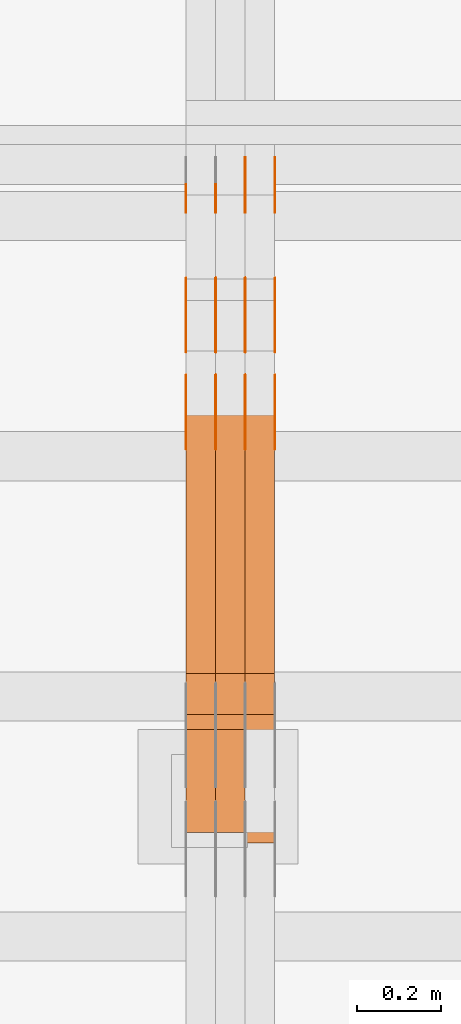
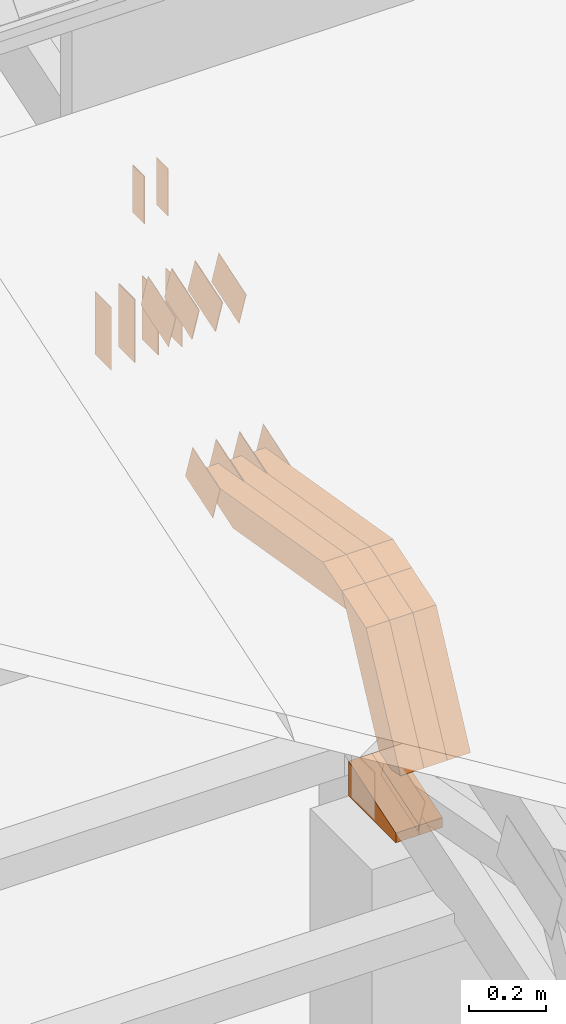
# One storey, part 143 of 385: 29 proxies.
"""IFC2X3 building model written with IfcOpenShell, lengths in millimetres."""

from ifc_helpers import new_model, entity, si_unit, converted_unit, derived_unit, direction, frame, frame_2d, origin, origin_2d_with_axis, place, context, subcontext, project, spatial, polyline, rectangle, outline, extrude, source, transform, mapped, material, type_object, type_shapes, element, save


model = new_model("IFC2X3")

# Units and contexts
model_context = context("Model", 3, precision=0.01, world=origin(), true_north=direction((6.12303176911189e-17, 1.0)))
body_context = subcontext(model_context, "Body", "Model", "MODEL_VIEW")
ifc_project = project(units=[si_unit("LENGTHUNIT", "METRE", prefix="MILLI"), si_unit("AREAUNIT", "SQUARE_METRE"), si_unit("VOLUMEUNIT", "CUBIC_METRE"), converted_unit("PLANEANGLEUNIT", "DEGREE", entity("IfcRatioMeasure", 0.0174532925199433), si_unit("PLANEANGLEUNIT", "RADIAN"), dimensions=[0, 0, 0, 0, 0, 0, 0]), si_unit("MASSUNIT", "GRAM", prefix="KILO"), derived_unit("MASSDENSITYUNIT", [(si_unit("MASSUNIT", "GRAM", prefix="KILO"), 1), (si_unit("LENGTHUNIT", "METRE"), -3)]), si_unit("TIMEUNIT", "SECOND"), si_unit("FREQUENCYUNIT", "HERTZ"), si_unit("THERMODYNAMICTEMPERATUREUNIT", "DEGREE_CELSIUS"), derived_unit("THERMALTRANSMITTANCEUNIT", [(si_unit("MASSUNIT", "GRAM", prefix="KILO"), 1), (si_unit("THERMODYNAMICTEMPERATUREUNIT", "KELVIN"), -1), (si_unit("TIMEUNIT", "SECOND"), -3)]), derived_unit("VOLUMETRICFLOWRATEUNIT", [(si_unit("LENGTHUNIT", "METRE"), 3), (si_unit("TIMEUNIT", "SECOND"), -1)]), si_unit("ELECTRICCURRENTUNIT", "AMPERE"), si_unit("ELECTRICVOLTAGEUNIT", "VOLT"), si_unit("POWERUNIT", "WATT"), si_unit("FORCEUNIT", "NEWTON", prefix="KILO"), si_unit("ILLUMINANCEUNIT", "LUX"), si_unit("LUMINOUSFLUXUNIT", "LUMEN"), si_unit("LUMINOUSINTENSITYUNIT", "CANDELA"), derived_unit("USERDEFINED", [(si_unit("MASSUNIT", "GRAM", prefix="KILO"), -1), (si_unit("LENGTHUNIT", "METRE"), -2), (si_unit("TIMEUNIT", "SECOND"), 3), (si_unit("LUMINOUSFLUXUNIT", "LUMEN"), 1)]), derived_unit("LINEARVELOCITYUNIT", [(si_unit("LENGTHUNIT", "METRE"), 1), (si_unit("TIMEUNIT", "SECOND"), -1)]), si_unit("PRESSUREUNIT", "PASCAL"), derived_unit("USERDEFINED", [(si_unit("LENGTHUNIT", "METRE"), -2), (si_unit("MASSUNIT", "GRAM", prefix="KILO"), 1), (si_unit("TIMEUNIT", "SECOND"), -2)])], contexts=[model_context])

# Site, building, storey
site_placement = place(None, origin())
site = spatial("IfcSite", under=ifc_project, at=site_placement, CompositionType="ELEMENT")
building_placement = place(site_placement, origin())
building = spatial("IfcBuilding", under=site, at=building_placement, CompositionType="ELEMENT")
storey_placement = place(building_placement, origin())
storey = spatial("IfcBuildingStorey", under=building, at=storey_placement, Name="Default", CompositionType="ELEMENT", Elevation=0.0)

# Proxies
ifc_material_1 = material(Name="IfcSurfaceStyle #243572")
building_element_proxy_type_1 = type_object("IfcBuildingElementProxyType", PredefinedType="NOTDEFINED", material=ifc_material_1)
shared_shape_1 = source(origin(), body_context, "Body", "SweptSolid", [
    extrude(rectangle(XDim=200.0, YDim=84.0, at=frame_2d((0.0, -7.105427357601e-15), x_axis=(1.0, 0.0))), frame((100.0, 42.0, 0.0), z_axis=(0.0, 0.0, 1.0), x_axis=(-1.0, 0.0, 0.0)), (0.0, 0.0, 1.0), 1.3),
])
type_shapes(building_element_proxy_type_1, [shared_shape_1])
proxy_1_placement = place(building_placement, frame((18386.3, 13702.0, 3651.4150390625), z_axis=(-1.0, 0.0, 0.0), x_axis=(0.0, 0.0, -1.0)))
element("IfcBuildingElementProxy", 1, at=proxy_1_placement, inside=storey, type_object=building_element_proxy_type_1, material=ifc_material_1, context=body_context, shape_type="MappedRepresentation", body=[
    mapped(shared_shape_1, transform((0.0, 0.0, 0.0), scale=1.0)),
])
ifc_material_2 = material(Name="IfcSurfaceStyle #243515")
building_element_proxy_type_2 = type_object("IfcBuildingElementProxyType", PredefinedType="NOTDEFINED", material=ifc_material_2)
shared_shape_2 = source(origin(), body_context, "Body", "SweptSolid", [
    extrude(rectangle(XDim=200.0, YDim=84.0, at=frame_2d((0.0, -7.105427357601e-15), x_axis=(1.0, 0.0))), frame((100.0, 42.0, 0.0), z_axis=(0.0, 0.0, 1.0), x_axis=(-1.0, 0.0, 0.0)), (0.0, 0.0, 1.0), 1.3),
])
type_shapes(building_element_proxy_type_2, [shared_shape_2])
proxy_2_placement = place(building_placement, frame((18315.0, 13702.0, 3651.4150390625), z_axis=(-1.0, 0.0, 0.0), x_axis=(0.0, 0.0, -1.0)))
element("IfcBuildingElementProxy", 2, at=proxy_2_placement, inside=storey, type_object=building_element_proxy_type_2, material=ifc_material_2, context=body_context, shape_type="MappedRepresentation", body=[
    mapped(shared_shape_2, transform((0.0, 0.0, 0.0), scale=1.0)),
])
ifc_material_3 = material(Name="IfcSurfaceStyle #243458")
building_element_proxy_type_3 = type_object("IfcBuildingElementProxyType", PredefinedType="NOTDEFINED", material=ifc_material_3)
shared_shape_3 = source(origin(), body_context, "Body", "SweptSolid", [
    extrude(rectangle(XDim=200.0, YDim=84.0, at=frame_2d((0.0, -7.105427357601e-15), x_axis=(1.0, 0.0))), frame((100.0, 42.0, 0.0), z_axis=(0.0, 0.0, 1.0), x_axis=(-1.0, 0.0, 0.0)), (0.0, 0.0, 1.0), 1.3),
])
type_shapes(building_element_proxy_type_3, [shared_shape_3])
proxy_3_placement = place(building_placement, frame((18316.3, 13702.0, 3651.4150390625), z_axis=(-1.0, 0.0, 0.0), x_axis=(0.0, 0.0, -1.0)))
element("IfcBuildingElementProxy", 3, at=proxy_3_placement, inside=storey, type_object=building_element_proxy_type_3, material=ifc_material_3, context=body_context, shape_type="MappedRepresentation", body=[
    mapped(shared_shape_3, transform((0.0, 0.0, 0.0), scale=1.0)),
])
ifc_material_4 = material(Name="IfcSurfaceStyle #243401")
building_element_proxy_type_4 = type_object("IfcBuildingElementProxyType", PredefinedType="NOTDEFINED", material=ifc_material_4)
shared_shape_4 = source(origin(), body_context, "Body", "SweptSolid", [
    extrude(rectangle(XDim=200.0, YDim=84.0, at=frame_2d((0.0, -7.105427357601e-15), x_axis=(1.0, 0.0))), frame((100.0, 42.0, 0.0), z_axis=(0.0, 0.0, 1.0), x_axis=(-1.0, 0.0, 0.0)), (0.0, 0.0, 1.0), 1.29999999999998),
])
type_shapes(building_element_proxy_type_4, [shared_shape_4])
proxy_4_placement = place(building_placement, frame((18245.0, 13702.0, 3651.4150390625), z_axis=(-1.0, 0.0, 0.0), x_axis=(0.0, 0.0, -1.0)))
element("IfcBuildingElementProxy", 4, at=proxy_4_placement, inside=storey, type_object=building_element_proxy_type_4, material=ifc_material_4, context=body_context, shape_type="MappedRepresentation", body=[
    mapped(shared_shape_4, transform((0.0, 0.0, 0.0), scale=1.0)),
])
ifc_material_5 = material(Name="IfcSurfaceStyle #243344")
building_element_proxy_type_5 = type_object("IfcBuildingElementProxyType", PredefinedType="NOTDEFINED", material=ifc_material_5)
shared_shape_5 = source(origin(), body_context, "Body", "SweptSolid", [
    extrude(rectangle(XDim=200.0, YDim=84.0, at=frame_2d((0.0, -7.105427357601e-15), x_axis=(1.0, 0.0))), frame((100.0, 42.0, 0.0), z_axis=(0.0, 0.0, 1.0), x_axis=(-1.0, 0.0, 0.0)), (0.0, 0.0, 1.0), 1.29999999999998),
])
type_shapes(building_element_proxy_type_5, [shared_shape_5])
proxy_5_placement = place(building_placement, frame((18246.3, 13702.0, 3651.4150390625), z_axis=(-1.0, 0.0, 0.0), x_axis=(0.0, 0.0, -1.0)))
element("IfcBuildingElementProxy", 5, at=proxy_5_placement, inside=storey, type_object=building_element_proxy_type_5, material=ifc_material_5, context=body_context, shape_type="MappedRepresentation", body=[
    mapped(shared_shape_5, transform((0.0, 0.0, 0.0), scale=1.0)),
])
ifc_material_6 = material(Name="IfcSurfaceStyle #243287")
building_element_proxy_type_6 = type_object("IfcBuildingElementProxyType", PredefinedType="NOTDEFINED", material=ifc_material_6)
shared_shape_6 = source(origin(), body_context, "Body", "SweptSolid", [
    extrude(rectangle(XDim=200.0, YDim=84.0, at=frame_2d((0.0, -7.105427357601e-15), x_axis=(1.0, 0.0))), frame((100.0, 42.0, 0.0), z_axis=(0.0, 0.0, 1.0), x_axis=(-1.0, 0.0, 0.0)), (0.0, 0.0, 1.0), 1.29999999999999),
])
type_shapes(building_element_proxy_type_6, [shared_shape_6])
proxy_6_placement = place(building_placement, frame((18175.0, 13702.0, 3651.4150390625), z_axis=(-1.0, 0.0, 0.0), x_axis=(0.0, 0.0, -1.0)))
element("IfcBuildingElementProxy", 6, at=proxy_6_placement, inside=storey, type_object=building_element_proxy_type_6, material=ifc_material_6, context=body_context, shape_type="MappedRepresentation", body=[
    mapped(shared_shape_6, transform((0.0, 0.0, 0.0), scale=1.0)),
])
ifc_material_7 = material(Name="IfcSurfaceStyle #243230")
building_element_proxy_type_7 = type_object("IfcBuildingElementProxyType", PredefinedType="NOTDEFINED", material=ifc_material_7)
shared_shape_7 = source(origin(), body_context, "Body", "SweptSolid", [
    extrude(outline(polyline([(-75.0003398116828, -59.9998507501386), (75.0003249421766, -59.9998507501386), (75.0003398116837, 59.9998507501387), (-75.0003249421775, 59.9998507501387), (-75.0003398116828, -59.9998507501386)])), frame((75.0003398116837, 60.0000773549637, 0.0), z_axis=(0.0, 0.0, 1.0), x_axis=(-1.0, 0.0, 0.0)), (0.0, 0.0, 1.0), 1.3),
])
type_shapes(building_element_proxy_type_7, [shared_shape_7])
proxy_7_placement = place(building_placement, frame((18386.3, 13054.73046875, 3417.8388671875), z_axis=(-1.0, 0.0, 0.0), x_axis=(0.0, 0.951056516295124, 0.309016994375039)))
element("IfcBuildingElementProxy", 7, at=proxy_7_placement, inside=storey, type_object=building_element_proxy_type_7, material=ifc_material_7, context=body_context, shape_type="MappedRepresentation", body=[
    mapped(shared_shape_7, transform((0.0, 0.0, 0.0), scale=1.0)),
])
ifc_material_8 = material(Name="IfcSurfaceStyle #243173")
building_element_proxy_type_8 = type_object("IfcBuildingElementProxyType", PredefinedType="NOTDEFINED", material=ifc_material_8)
shared_shape_8 = source(origin(), body_context, "Body", "SweptSolid", [
    extrude(outline(polyline([(-75.0003398116828, -59.9998507501386), (75.0003249421766, -59.9998507501386), (75.0003398116837, 59.9998507501387), (-75.0003249421775, 59.9998507501387), (-75.0003398116828, -59.9998507501386)])), frame((75.0003398116837, 60.0000773549637, 0.0), z_axis=(0.0, 0.0, 1.0), x_axis=(-1.0, 0.0, 0.0)), (0.0, 0.0, 1.0), 1.3),
])
type_shapes(building_element_proxy_type_8, [shared_shape_8])
proxy_8_placement = place(building_placement, frame((18315.0, 13054.73046875, 3417.8388671875), z_axis=(-1.0, 0.0, 0.0), x_axis=(0.0, 0.951056516295124, 0.309016994375039)))
element("IfcBuildingElementProxy", 8, at=proxy_8_placement, inside=storey, type_object=building_element_proxy_type_8, material=ifc_material_8, context=body_context, shape_type="MappedRepresentation", body=[
    mapped(shared_shape_8, transform((0.0, 0.0, 0.0), scale=1.0)),
])
ifc_material_9 = material(Name="IfcSurfaceStyle #243116")
building_element_proxy_type_9 = type_object("IfcBuildingElementProxyType", PredefinedType="NOTDEFINED", material=ifc_material_9)
shared_shape_9 = source(origin(), body_context, "Body", "SweptSolid", [
    extrude(outline(polyline([(-75.0003398116828, -59.9998507501386), (75.0003249421766, -59.9998507501386), (75.0003398116837, 59.9998507501387), (-75.0003249421775, 59.9998507501387), (-75.0003398116828, -59.9998507501386)])), frame((75.0003398116837, 60.0000773549637, 0.0), z_axis=(0.0, 0.0, 1.0), x_axis=(-1.0, 0.0, 0.0)), (0.0, 0.0, 1.0), 1.3),
])
type_shapes(building_element_proxy_type_9, [shared_shape_9])
proxy_9_placement = place(building_placement, frame((18316.3, 13054.73046875, 3417.8388671875), z_axis=(-1.0, 0.0, 0.0), x_axis=(0.0, 0.951056516295124, 0.309016994375039)))
element("IfcBuildingElementProxy", 9, at=proxy_9_placement, inside=storey, type_object=building_element_proxy_type_9, material=ifc_material_9, context=body_context, shape_type="MappedRepresentation", body=[
    mapped(shared_shape_9, transform((0.0, 0.0, 0.0), scale=1.0)),
])
ifc_material_10 = material(Name="IfcSurfaceStyle #243059")
building_element_proxy_type_10 = type_object("IfcBuildingElementProxyType", PredefinedType="NOTDEFINED", material=ifc_material_10)
shared_shape_10 = source(origin(), body_context, "Body", "SweptSolid", [
    extrude(outline(polyline([(-75.0003398116828, -59.9998507501386), (75.0003249421766, -59.9998507501386), (75.0003398116837, 59.9998507501387), (-75.0003249421775, 59.9998507501387), (-75.0003398116828, -59.9998507501386)])), frame((75.0003398116837, 60.0000773549637, 0.0), z_axis=(0.0, 0.0, 1.0), x_axis=(-1.0, 0.0, 0.0)), (0.0, 0.0, 1.0), 1.29999999999999),
])
type_shapes(building_element_proxy_type_10, [shared_shape_10])
proxy_10_placement = place(building_placement, frame((18245.0, 13054.73046875, 3417.8388671875), z_axis=(-1.0, 0.0, 0.0), x_axis=(0.0, 0.951056516295124, 0.309016994375039)))
element("IfcBuildingElementProxy", 10, at=proxy_10_placement, inside=storey, type_object=building_element_proxy_type_10, material=ifc_material_10, context=body_context, shape_type="MappedRepresentation", body=[
    mapped(shared_shape_10, transform((0.0, 0.0, 0.0), scale=1.0)),
])
ifc_material_11 = material(Name="IfcSurfaceStyle #243002")
building_element_proxy_type_11 = type_object("IfcBuildingElementProxyType", PredefinedType="NOTDEFINED", material=ifc_material_11)
shared_shape_11 = source(origin(), body_context, "Body", "SweptSolid", [
    extrude(outline(polyline([(-75.0003398116828, -59.9998507501386), (75.0003249421766, -59.9998507501386), (75.0003398116837, 59.9998507501387), (-75.0003249421775, 59.9998507501387), (-75.0003398116828, -59.9998507501386)])), frame((75.0003398116837, 60.0000773549637, 0.0), z_axis=(0.0, 0.0, 1.0), x_axis=(-1.0, 0.0, 0.0)), (0.0, 0.0, 1.0), 1.29999999999999),
])
type_shapes(building_element_proxy_type_11, [shared_shape_11])
proxy_11_placement = place(building_placement, frame((18246.3, 13054.73046875, 3417.8388671875), z_axis=(-1.0, 0.0, 0.0), x_axis=(0.0, 0.951056516295124, 0.309016994375039)))
element("IfcBuildingElementProxy", 11, at=proxy_11_placement, inside=storey, type_object=building_element_proxy_type_11, material=ifc_material_11, context=body_context, shape_type="MappedRepresentation", body=[
    mapped(shared_shape_11, transform((0.0, 0.0, 0.0), scale=1.0)),
])
ifc_material_12 = material(Name="IfcSurfaceStyle #242945")
building_element_proxy_type_12 = type_object("IfcBuildingElementProxyType", PredefinedType="NOTDEFINED", material=ifc_material_12)
shared_shape_12 = source(origin(), body_context, "Body", "SweptSolid", [
    extrude(outline(polyline([(-75.0003398116828, -59.9998507501386), (75.0003249421766, -59.9998507501386), (75.0003398116837, 59.9998507501387), (-75.0003249421775, 59.9998507501387), (-75.0003398116828, -59.9998507501386)])), frame((75.0003398116837, 60.0000773549637, 0.0), z_axis=(0.0, 0.0, 1.0), x_axis=(-1.0, 0.0, 0.0)), (0.0, 0.0, 1.0), 1.29999999999999),
])
type_shapes(building_element_proxy_type_12, [shared_shape_12])
proxy_12_placement = place(building_placement, frame((18175.0, 13054.73046875, 3417.8388671875), z_axis=(-1.0, 0.0, 0.0), x_axis=(0.0, 0.951056516295124, 0.309016994375039)))
element("IfcBuildingElementProxy", 12, at=proxy_12_placement, inside=storey, type_object=building_element_proxy_type_12, material=ifc_material_12, context=body_context, shape_type="MappedRepresentation", body=[
    mapped(shared_shape_12, transform((0.0, 0.0, 0.0), scale=1.0)),
])
ifc_material_13 = material(Name="IfcSurfaceStyle #235364")
building_element_proxy_type_13 = type_object("IfcBuildingElementProxyType", PredefinedType="NOTDEFINED", material=ifc_material_13)
shared_shape_13 = source(origin(), body_context, "Body", "SweptSolid", [
    extrude(outline(polyline([(-74.999875428623, -60.0000016373506), (74.9998605591059, -60.0000016373506), (74.9998754286239, 60.0000016373506), (-74.9998605591068, 60.0000016373506), (-74.999875428623, -60.0000016373506)])), frame((75.0002691827262, 60.0000190504561, 0.0), z_axis=(0.0, 0.0, 1.0), x_axis=(-1.0, 0.0, 0.0)), (0.0, 0.0, 1.0), 1.3),
])
type_shapes(building_element_proxy_type_13, [shared_shape_13])
proxy_13_placement = place(building_placement, frame((18386.3, 13285.0865109705, 3819.37496637467), z_axis=(-1.0, 0.0, 0.0), x_axis=(0.0, 0.951056516295154, 0.309016994374948)))
element("IfcBuildingElementProxy", 13, at=proxy_13_placement, inside=storey, type_object=building_element_proxy_type_13, material=ifc_material_13, context=body_context, shape_type="MappedRepresentation", body=[
    mapped(shared_shape_13, transform((0.0, 0.0, 0.0), scale=1.0)),
])
ifc_material_14 = material(Name="IfcSurfaceStyle #235307")
building_element_proxy_type_14 = type_object("IfcBuildingElementProxyType", PredefinedType="NOTDEFINED", material=ifc_material_14)
shared_shape_14 = source(origin(), body_context, "Body", "SweptSolid", [
    extrude(outline(polyline([(-74.999875428623, -60.0000016373506), (74.9998605591059, -60.0000016373506), (74.9998754286239, 60.0000016373506), (-74.9998605591068, 60.0000016373506), (-74.999875428623, -60.0000016373506)])), frame((75.0002691827262, 60.0000190504561, 0.0), z_axis=(0.0, 0.0, 1.0), x_axis=(-1.0, 0.0, 0.0)), (0.0, 0.0, 1.0), 1.3),
])
type_shapes(building_element_proxy_type_14, [shared_shape_14])
proxy_14_placement = place(building_placement, frame((18315.0, 13285.0865109705, 3819.37496637467), z_axis=(-1.0, 0.0, 0.0), x_axis=(0.0, 0.951056516295154, 0.309016994374948)))
element("IfcBuildingElementProxy", 14, at=proxy_14_placement, inside=storey, type_object=building_element_proxy_type_14, material=ifc_material_14, context=body_context, shape_type="MappedRepresentation", body=[
    mapped(shared_shape_14, transform((0.0, 0.0, 0.0), scale=1.0)),
])
ifc_material_15 = material(Name="IfcSurfaceStyle #235250")
building_element_proxy_type_15 = type_object("IfcBuildingElementProxyType", PredefinedType="NOTDEFINED", material=ifc_material_15)
shared_shape_15 = source(origin(), body_context, "Body", "SweptSolid", [
    extrude(outline(polyline([(-74.999875428623, -60.0000016373506), (74.9998605591059, -60.0000016373506), (74.9998754286239, 60.0000016373506), (-74.9998605591068, 60.0000016373506), (-74.999875428623, -60.0000016373506)])), frame((75.0002691827262, 60.0000190504561, 0.0), z_axis=(0.0, 0.0, 1.0), x_axis=(-1.0, 0.0, 0.0)), (0.0, 0.0, 1.0), 1.3),
])
type_shapes(building_element_proxy_type_15, [shared_shape_15])
proxy_15_placement = place(building_placement, frame((18316.3, 13285.0865109705, 3819.37496637467), z_axis=(-1.0, 0.0, 0.0), x_axis=(0.0, 0.951056516295154, 0.309016994374948)))
element("IfcBuildingElementProxy", 15, at=proxy_15_placement, inside=storey, type_object=building_element_proxy_type_15, material=ifc_material_15, context=body_context, shape_type="MappedRepresentation", body=[
    mapped(shared_shape_15, transform((0.0, 0.0, 0.0), scale=1.0)),
])
ifc_material_16 = material(Name="IfcSurfaceStyle #235193")
building_element_proxy_type_16 = type_object("IfcBuildingElementProxyType", PredefinedType="NOTDEFINED", material=ifc_material_16)
shared_shape_16 = source(origin(), body_context, "Body", "SweptSolid", [
    extrude(outline(polyline([(-74.999875428623, -60.0000016373506), (74.9998605591059, -60.0000016373506), (74.9998754286239, 60.0000016373506), (-74.9998605591068, 60.0000016373506), (-74.999875428623, -60.0000016373506)])), frame((75.0002691827262, 60.0000190504561, 0.0), z_axis=(0.0, 0.0, 1.0), x_axis=(-1.0, 0.0, 0.0)), (0.0, 0.0, 1.0), 1.29999999999999),
])
type_shapes(building_element_proxy_type_16, [shared_shape_16])
proxy_16_placement = place(building_placement, frame((18245.0, 13285.0865109705, 3819.37496637467), z_axis=(-1.0, 0.0, 0.0), x_axis=(0.0, 0.951056516295154, 0.309016994374948)))
element("IfcBuildingElementProxy", 16, at=proxy_16_placement, inside=storey, type_object=building_element_proxy_type_16, material=ifc_material_16, context=body_context, shape_type="MappedRepresentation", body=[
    mapped(shared_shape_16, transform((0.0, 0.0, 0.0), scale=1.0)),
])
ifc_material_17 = material(Name="IfcSurfaceStyle #235136")
building_element_proxy_type_17 = type_object("IfcBuildingElementProxyType", PredefinedType="NOTDEFINED", material=ifc_material_17)
shared_shape_17 = source(origin(), body_context, "Body", "SweptSolid", [
    extrude(outline(polyline([(-74.999875428623, -60.0000016373506), (74.9998605591059, -60.0000016373506), (74.9998754286239, 60.0000016373506), (-74.9998605591068, 60.0000016373506), (-74.999875428623, -60.0000016373506)])), frame((75.0002691827262, 60.0000190504561, 0.0), z_axis=(0.0, 0.0, 1.0), x_axis=(-1.0, 0.0, 0.0)), (0.0, 0.0, 1.0), 1.29999999999999),
])
type_shapes(building_element_proxy_type_17, [shared_shape_17])
proxy_17_placement = place(building_placement, frame((18246.3, 13285.0865109705, 3819.37496637467), z_axis=(-1.0, 0.0, 0.0), x_axis=(0.0, 0.951056516295154, 0.309016994374948)))
element("IfcBuildingElementProxy", 17, at=proxy_17_placement, inside=storey, type_object=building_element_proxy_type_17, material=ifc_material_17, context=body_context, shape_type="MappedRepresentation", body=[
    mapped(shared_shape_17, transform((0.0, 0.0, 0.0), scale=1.0)),
])
ifc_material_18 = material(Name="IfcSurfaceStyle #235079")
building_element_proxy_type_18 = type_object("IfcBuildingElementProxyType", PredefinedType="NOTDEFINED", material=ifc_material_18)
shared_shape_18 = source(origin(), body_context, "Body", "SweptSolid", [
    extrude(outline(polyline([(-74.999875428623, -60.0000016373506), (74.9998605591059, -60.0000016373506), (74.9998754286239, 60.0000016373506), (-74.9998605591068, 60.0000016373506), (-74.999875428623, -60.0000016373506)])), frame((75.0002691827262, 60.0000190504561, 0.0), z_axis=(0.0, 0.0, 1.0), x_axis=(-1.0, 0.0, 0.0)), (0.0, 0.0, 1.0), 1.29999999999999),
])
type_shapes(building_element_proxy_type_18, [shared_shape_18])
proxy_18_placement = place(building_placement, frame((18175.0, 13285.0865109705, 3819.37496637467), z_axis=(-1.0, 0.0, 0.0), x_axis=(0.0, 0.951056516295154, 0.309016994374948)))
element("IfcBuildingElementProxy", 18, at=proxy_18_placement, inside=storey, type_object=building_element_proxy_type_18, material=ifc_material_18, context=body_context, shape_type="MappedRepresentation", body=[
    mapped(shared_shape_18, transform((0.0, 0.0, 0.0), scale=1.0)),
])
ifc_material_19 = material(Name="IfcSurfaceStyle #234680")
building_element_proxy_type_19 = type_object("IfcBuildingElementProxyType", PredefinedType="NOTDEFINED", material=ifc_material_19)
shared_shape_19 = source(origin(), body_context, "Body", "SweptSolid", [
    extrude(rectangle(XDim=150.0, YDim=60.0, at=origin_2d_with_axis()), frame((75.0000705696166, 30.0, 0.0), z_axis=(0.0, 0.0, 1.0), x_axis=(-1.0, 0.0, 0.0)), (0.0, 0.0, 1.0), 1.3),
])
type_shapes(building_element_proxy_type_19, [shared_shape_19])
proxy_19_placement = place(building_placement, frame((18386.3, 13750.0, 3972.59919166337), z_axis=(-1.0, 0.0, 0.0), x_axis=(0.0, 0.0, -1.0)))
element("IfcBuildingElementProxy", 19, at=proxy_19_placement, inside=storey, type_object=building_element_proxy_type_19, material=ifc_material_19, context=body_context, shape_type="MappedRepresentation", body=[
    mapped(shared_shape_19, transform((0.0, 0.0, 0.0), scale=1.0)),
])
ifc_material_20 = material(Name="IfcSurfaceStyle #234623")
building_element_proxy_type_20 = type_object("IfcBuildingElementProxyType", PredefinedType="NOTDEFINED", material=ifc_material_20)
shared_shape_20 = source(origin(), body_context, "Body", "SweptSolid", [
    extrude(rectangle(XDim=150.0, YDim=60.0, at=origin_2d_with_axis()), frame((75.0000705696166, 30.0, 0.0), z_axis=(0.0, 0.0, 1.0), x_axis=(-1.0, 0.0, 0.0)), (0.0, 0.0, 1.0), 1.3),
])
type_shapes(building_element_proxy_type_20, [shared_shape_20])
proxy_20_placement = place(building_placement, frame((18315.0, 13750.0, 3972.59919166337), z_axis=(-1.0, 0.0, 0.0), x_axis=(0.0, 0.0, -1.0)))
element("IfcBuildingElementProxy", 20, at=proxy_20_placement, inside=storey, type_object=building_element_proxy_type_20, material=ifc_material_20, context=body_context, shape_type="MappedRepresentation", body=[
    mapped(shared_shape_20, transform((0.0, 0.0, 0.0), scale=1.0)),
])
ifc_material_21 = material(Name="IfcSurfaceStyle #234566")
building_element_proxy_type_21 = type_object("IfcBuildingElementProxyType", PredefinedType="NOTDEFINED", material=ifc_material_21)
shared_shape_21 = source(origin(), body_context, "Body", "SweptSolid", [
    extrude(rectangle(XDim=150.0, YDim=60.0, at=origin_2d_with_axis()), frame((75.0000705696166, 30.0, 0.0), z_axis=(0.0, 0.0, 1.0), x_axis=(-1.0, 0.0, 0.0)), (0.0, 0.0, 1.0), 1.3),
])
type_shapes(building_element_proxy_type_21, [shared_shape_21])
proxy_21_placement = place(building_placement, frame((18316.3, 13750.0, 3972.59919166337), z_axis=(-1.0, 0.0, 0.0), x_axis=(0.0, 0.0, -1.0)))
element("IfcBuildingElementProxy", 21, at=proxy_21_placement, inside=storey, type_object=building_element_proxy_type_21, material=ifc_material_21, context=body_context, shape_type="MappedRepresentation", body=[
    mapped(shared_shape_21, transform((0.0, 0.0, 0.0), scale=1.0)),
])
ifc_material_22 = material(Name="IfcSurfaceStyle #225479")
building_element_proxy_type_22 = type_object("IfcBuildingElementProxyType", Name="T1-E1 225477", PredefinedType="NOTDEFINED", material=ifc_material_22)
shared_shape_22 = source(origin(), body_context, "Body", "SweptSolid", [
    extrude(outline(polyline([(-75.1378173828004, -122.500000000005), (35.3350830078246, -122.500000000005), (35.3350830078004, 122.500000000005), (4.46765136717545, 122.500000000005), (-75.1378173828004, -122.500000000005)])), frame((35.3350830078246, 122.500000104877, 0.0), z_axis=(0.0, 0.0, 1.0), x_axis=(-1.0, 0.0, 0.0)), (0.0, 0.0, 1.0), 70.0),
])
type_shapes(building_element_proxy_type_22, [shared_shape_22])
proxy_22_placement = place(building_placement, frame((18315.0, 12145.0, 2849.54565429685), z_axis=(-1.0, 0.0, 0.0), x_axis=(0.0, 0.0, 1.0)))
element("IfcBuildingElementProxy", 22, at=proxy_22_placement, inside=storey, type_object=building_element_proxy_type_22, material=ifc_material_22, Name="T1-E1", context=body_context, shape_type="MappedRepresentation", body=[
    mapped(shared_shape_22, transform((0.0, 0.0, 0.0), scale=1.0)),
])
ifc_material_23 = material(Name="IfcSurfaceStyle #225422")
building_element_proxy_type_23 = type_object("IfcBuildingElementProxyType", Name="T1-E1 225420", PredefinedType="NOTDEFINED", material=ifc_material_23)
shared_shape_23 = source(origin(), body_context, "Body", "SweptSolid", [
    extrude(outline(polyline([(-75.1378173828004, -122.500000000005), (35.3350830078246, -122.500000000005), (35.3350830078004, 122.500000000005), (4.46765136717545, 122.500000000005), (-75.1378173828004, -122.500000000005)])), frame((35.3350830078246, 122.500000104877, 0.0), z_axis=(0.0, 0.0, 1.0), x_axis=(-1.0, 0.0, 0.0)), (0.0, 0.0, 1.0), 70.0),
])
type_shapes(building_element_proxy_type_23, [shared_shape_23])
proxy_23_placement = place(building_placement, frame((18245.0, 12145.0, 2849.54565429685), z_axis=(-1.0, 0.0, 0.0), x_axis=(0.0, 0.0, 1.0)))
element("IfcBuildingElementProxy", 23, at=proxy_23_placement, inside=storey, type_object=building_element_proxy_type_23, material=ifc_material_23, Name="T1-E1", context=body_context, shape_type="MappedRepresentation", body=[
    mapped(shared_shape_23, transform((0.0, 0.0, 0.0), scale=1.0)),
])
ifc_material_24 = material(Name="IfcSurfaceStyle #223808")
building_element_proxy_type_24 = type_object("IfcBuildingElementProxyType", Name="T1-W7 223806", PredefinedType="NOTDEFINED", material=ifc_material_24)
shared_shape_24 = source(origin(), body_context, "Body", "SweptSolid", [
    extrude(outline(polyline([(-296.174043820986, -47.5000676566704), (297.841254477443, -47.5000676566704), (283.518570346415, -7.10254316533821e-06), (192.674144473719, 47.500071207942), (-477.859925476591, 47.500071207942), (-296.174043820986, -47.5000676566704)])), frame((297.841254477443, 47.5000816097442, 0.0), z_axis=(0.0, 0.0, 1.0), x_axis=(-1.0, 0.0, 0.0)), (0.0, 0.0, 1.0), 70.0),
])
type_shapes(building_element_proxy_type_24, [shared_shape_24])
proxy_24_placement = place(building_placement, frame((18385.0, 12419.2991208897, 3526.2136755972), z_axis=(-1.0, 0.0, 0.0), x_axis=(0.0, 0.985983815111804, -0.166840991178939)))
element("IfcBuildingElementProxy", 24, at=proxy_24_placement, inside=storey, type_object=building_element_proxy_type_24, material=ifc_material_24, Name="T1-W7", context=body_context, shape_type="MappedRepresentation", body=[
    mapped(shared_shape_24, transform((0.0, 0.0, 0.0), scale=1.0)),
])
ifc_material_25 = material(Name="IfcSurfaceStyle #223742")
building_element_proxy_type_25 = type_object("IfcBuildingElementProxyType", Name="T1-W7 223740", PredefinedType="NOTDEFINED", material=ifc_material_25)
shared_shape_25 = source(origin(), body_context, "Body", "SweptSolid", [
    extrude(outline(polyline([(-296.174043820986, -47.5000676566704), (297.841254477443, -47.5000676566704), (283.518570346415, -7.10254316533821e-06), (192.674144473719, 47.500071207942), (-477.859925476591, 47.500071207942), (-296.174043820986, -47.5000676566704)])), frame((297.841254477443, 47.5000816097442, 0.0), z_axis=(0.0, 0.0, 1.0), x_axis=(-1.0, 0.0, 0.0)), (0.0, 0.0, 1.0), 70.0),
])
type_shapes(building_element_proxy_type_25, [shared_shape_25])
proxy_25_placement = place(building_placement, frame((18315.0, 12419.2991208897, 3526.2136755972), z_axis=(-1.0, 0.0, 0.0), x_axis=(0.0, 0.985983815111804, -0.166840991178939)))
element("IfcBuildingElementProxy", 25, at=proxy_25_placement, inside=storey, type_object=building_element_proxy_type_25, material=ifc_material_25, Name="T1-W7", context=body_context, shape_type="MappedRepresentation", body=[
    mapped(shared_shape_25, transform((0.0, 0.0, 0.0), scale=1.0)),
])
ifc_material_26 = material(Name="IfcSurfaceStyle #223676")
building_element_proxy_type_26 = type_object("IfcBuildingElementProxyType", Name="T1-W7 223674", PredefinedType="NOTDEFINED", material=ifc_material_26)
shared_shape_26 = source(origin(), body_context, "Body", "SweptSolid", [
    extrude(outline(polyline([(-296.174043820986, -47.5000676566704), (297.841254477443, -47.5000676566704), (283.518570346415, -7.10254316533821e-06), (192.674144473719, 47.500071207942), (-477.859925476591, 47.500071207942), (-296.174043820986, -47.5000676566704)])), frame((297.841254477443, 47.5000816097442, 0.0), z_axis=(0.0, 0.0, 1.0), x_axis=(-1.0, 0.0, 0.0)), (0.0, 0.0, 1.0), 70.0),
])
type_shapes(building_element_proxy_type_26, [shared_shape_26])
proxy_26_placement = place(building_placement, frame((18245.0, 12419.2991208897, 3526.2136755972), z_axis=(-1.0, 0.0, 0.0), x_axis=(0.0, 0.985983815111804, -0.166840991178939)))
element("IfcBuildingElementProxy", 26, at=proxy_26_placement, inside=storey, type_object=building_element_proxy_type_26, material=ifc_material_26, Name="T1-W7", context=body_context, shape_type="MappedRepresentation", body=[
    mapped(shared_shape_26, transform((0.0, 0.0, 0.0), scale=1.0)),
])
ifc_material_27 = material(Name="IfcSurfaceStyle #223412")
building_element_proxy_type_27 = type_object("IfcBuildingElementProxyType", Name="T1-W36 223410", PredefinedType="NOTDEFINED", material=ifc_material_27)
shared_shape_27 = source(origin(), body_context, "Body", "SweptSolid", [
    extrude(outline(polyline([(-300.714670922549, -47.4998881108849), (134.031527004269, -47.499888110885), (180.52054953879, -0.000136170977331764), (193.89900152221, 47.500563476126), (-207.736407142719, 47.4993489166213), (-300.714670922549, -47.4998881108849)])), frame((193.899145164686, 47.5001861375837, 0.0), z_axis=(0.0, 0.0, 1.0), x_axis=(-1.0, 3.02403492980632e-06, 0.0)), (0.0, 0.0, 1.0), 70.0),
])
type_shapes(building_element_proxy_type_27, [shared_shape_27])
proxy_27_placement = place(building_placement, frame((18385.0, 12120.5935627532, 3076.1128858536), z_axis=(-1.0, 0.0, 0.0), x_axis=(0.0, 0.444384650266842, 0.895836080210669)))
element("IfcBuildingElementProxy", 27, at=proxy_27_placement, inside=storey, type_object=building_element_proxy_type_27, material=ifc_material_27, Name="T1-W36", context=body_context, shape_type="MappedRepresentation", body=[
    mapped(shared_shape_27, transform((0.0, 0.0, 0.0), scale=1.0)),
])
ifc_material_28 = material(Name="IfcSurfaceStyle #223346")
building_element_proxy_type_28 = type_object("IfcBuildingElementProxyType", Name="T1-W36 223344", PredefinedType="NOTDEFINED", material=ifc_material_28)
shared_shape_28 = source(origin(), body_context, "Body", "SweptSolid", [
    extrude(outline(polyline([(-300.714670922549, -47.4998881108849), (134.031527004269, -47.499888110885), (180.52054953879, -0.000136170977331764), (193.89900152221, 47.500563476126), (-207.736407142719, 47.4993489166213), (-300.714670922549, -47.4998881108849)])), frame((193.899145164686, 47.5001861375837, 0.0), z_axis=(0.0, 0.0, 1.0), x_axis=(-1.0, 3.02403492980632e-06, 0.0)), (0.0, 0.0, 1.0), 70.0),
])
type_shapes(building_element_proxy_type_28, [shared_shape_28])
proxy_28_placement = place(building_placement, frame((18315.0, 12120.5935627532, 3076.1128858536), z_axis=(-1.0, 0.0, 0.0), x_axis=(0.0, 0.444384650266842, 0.895836080210669)))
element("IfcBuildingElementProxy", 28, at=proxy_28_placement, inside=storey, type_object=building_element_proxy_type_28, material=ifc_material_28, Name="T1-W36", context=body_context, shape_type="MappedRepresentation", body=[
    mapped(shared_shape_28, transform((0.0, 0.0, 0.0), scale=1.0)),
])
ifc_material_29 = material(Name="IfcSurfaceStyle #223280")
building_element_proxy_type_29 = type_object("IfcBuildingElementProxyType", Name="T1-W36 223278", PredefinedType="NOTDEFINED", material=ifc_material_29)
shared_shape_29 = source(origin(), body_context, "Body", "SweptSolid", [
    extrude(outline(polyline([(-300.714670922549, -47.4998881108849), (134.031527004269, -47.499888110885), (180.52054953879, -0.000136170977331764), (193.89900152221, 47.500563476126), (-207.736407142719, 47.4993489166213), (-300.714670922549, -47.4998881108849)])), frame((193.899145164686, 47.5001861375837, 0.0), z_axis=(0.0, 0.0, 1.0), x_axis=(-1.0, 3.02403492980632e-06, 0.0)), (0.0, 0.0, 1.0), 70.0),
])
type_shapes(building_element_proxy_type_29, [shared_shape_29])
proxy_29_placement = place(building_placement, frame((18245.0, 12120.5935627532, 3076.1128858536), z_axis=(-1.0, 0.0, 0.0), x_axis=(0.0, 0.444384650266842, 0.895836080210669)))
element("IfcBuildingElementProxy", 29, at=proxy_29_placement, inside=storey, type_object=building_element_proxy_type_29, material=ifc_material_29, Name="T1-W36", context=body_context, shape_type="MappedRepresentation", body=[
    mapped(shared_shape_29, transform((0.0, 0.0, 0.0), scale=1.0)),
])

save(model, "model.ifc")
